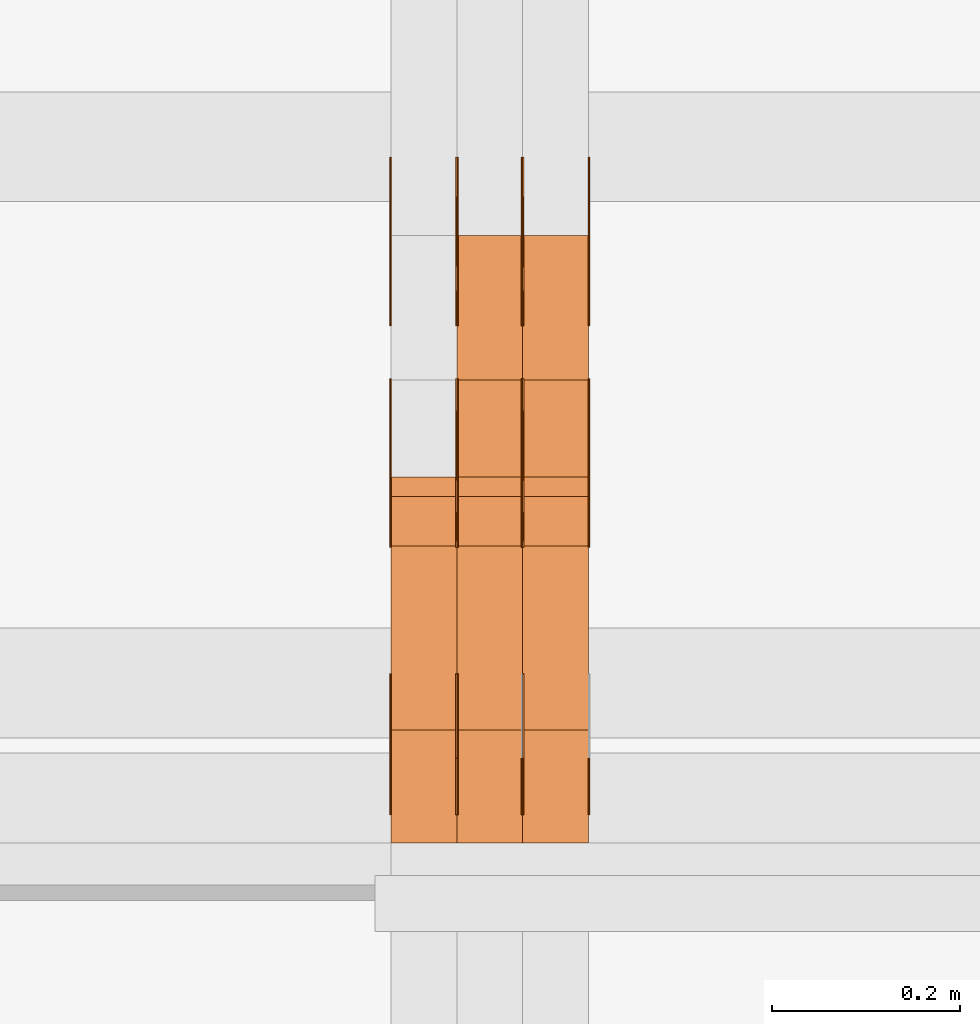
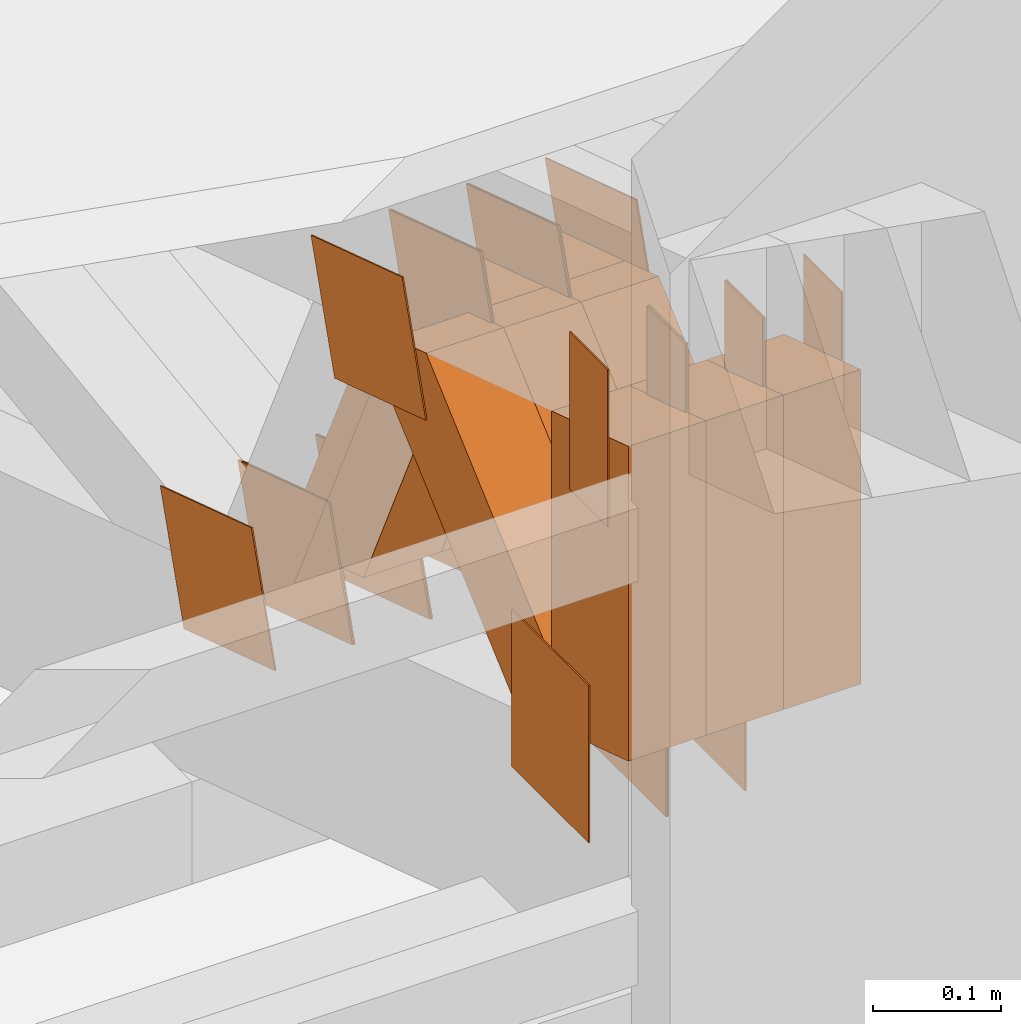
# One storey, part 150 of 385: 30 proxies.
"""IFC2X3 building model written with IfcOpenShell, lengths in millimetres."""

from ifc_helpers import new_model, entity, si_unit, converted_unit, derived_unit, direction, frame, origin, origin_2d_with_axis, place, context, subcontext, project, spatial, polyline, rectangle, outline, extrude, source, transform, mapped, material, type_object, type_shapes, element, save


model = new_model("IFC2X3")

# Units and contexts
model_context = context("Model", 3, precision=0.01, world=origin(), true_north=direction((6.12303176911189e-17, 1.0)))
body_context = subcontext(model_context, "Body", "Model", "MODEL_VIEW")
ifc_project = project(units=[si_unit("LENGTHUNIT", "METRE", prefix="MILLI"), si_unit("AREAUNIT", "SQUARE_METRE"), si_unit("VOLUMEUNIT", "CUBIC_METRE"), converted_unit("PLANEANGLEUNIT", "DEGREE", entity("IfcRatioMeasure", 0.0174532925199433), si_unit("PLANEANGLEUNIT", "RADIAN"), dimensions=[0, 0, 0, 0, 0, 0, 0]), si_unit("MASSUNIT", "GRAM", prefix="KILO"), derived_unit("MASSDENSITYUNIT", [(si_unit("MASSUNIT", "GRAM", prefix="KILO"), 1), (si_unit("LENGTHUNIT", "METRE"), -3)]), si_unit("TIMEUNIT", "SECOND"), si_unit("FREQUENCYUNIT", "HERTZ"), si_unit("THERMODYNAMICTEMPERATUREUNIT", "DEGREE_CELSIUS"), derived_unit("THERMALTRANSMITTANCEUNIT", [(si_unit("MASSUNIT", "GRAM", prefix="KILO"), 1), (si_unit("THERMODYNAMICTEMPERATUREUNIT", "KELVIN"), -1), (si_unit("TIMEUNIT", "SECOND"), -3)]), derived_unit("VOLUMETRICFLOWRATEUNIT", [(si_unit("LENGTHUNIT", "METRE"), 3), (si_unit("TIMEUNIT", "SECOND"), -1)]), si_unit("ELECTRICCURRENTUNIT", "AMPERE"), si_unit("ELECTRICVOLTAGEUNIT", "VOLT"), si_unit("POWERUNIT", "WATT"), si_unit("FORCEUNIT", "NEWTON", prefix="KILO"), si_unit("ILLUMINANCEUNIT", "LUX"), si_unit("LUMINOUSFLUXUNIT", "LUMEN"), si_unit("LUMINOUSINTENSITYUNIT", "CANDELA"), derived_unit("USERDEFINED", [(si_unit("MASSUNIT", "GRAM", prefix="KILO"), -1), (si_unit("LENGTHUNIT", "METRE"), -2), (si_unit("TIMEUNIT", "SECOND"), 3), (si_unit("LUMINOUSFLUXUNIT", "LUMEN"), 1)]), derived_unit("LINEARVELOCITYUNIT", [(si_unit("LENGTHUNIT", "METRE"), 1), (si_unit("TIMEUNIT", "SECOND"), -1)]), si_unit("PRESSUREUNIT", "PASCAL"), derived_unit("USERDEFINED", [(si_unit("LENGTHUNIT", "METRE"), -2), (si_unit("MASSUNIT", "GRAM", prefix="KILO"), 1), (si_unit("TIMEUNIT", "SECOND"), -2)])], contexts=[model_context])

# Site, building, storey
site_placement = place(None, origin())
site = spatial("IfcSite", under=ifc_project, at=site_placement, CompositionType="ELEMENT")
building_placement = place(site_placement, origin())
building = spatial("IfcBuilding", under=site, at=building_placement, CompositionType="ELEMENT")
storey_placement = place(building_placement, origin())
storey = spatial("IfcBuildingStorey", under=building, at=storey_placement, Name="Default", CompositionType="ELEMENT", Elevation=0.0)

# Proxies
ifc_material_1 = material(Name="IfcSurfaceStyle #274128")
building_element_proxy_type_1 = type_object("IfcBuildingElementProxyType", PredefinedType="NOTDEFINED", material=ifc_material_1)
shared_shape_1 = source(origin(), body_context, "Body", "SweptSolid", [
    extrude(rectangle(XDim=150.0, YDim=120.0, at=origin_2d_with_axis()), frame((75.0, 60.0, 0.0), z_axis=(0.0, 0.0, 1.0), x_axis=(-1.0, 0.0, 0.0)), (0.0, 0.0, 1.0), 1.3),
])
type_shapes(building_element_proxy_type_1, [shared_shape_1])
proxy_1_placement = place(building_placement, frame((21316.3, 15840.0, 3652.70166015625), z_axis=(-1.0, 0.0, 0.0), x_axis=(0.0, 0.0, -1.0)))
element("IfcBuildingElementProxy", 1, at=proxy_1_placement, inside=storey, type_object=building_element_proxy_type_1, material=ifc_material_1, context=body_context, shape_type="MappedRepresentation", body=[
    mapped(shared_shape_1, transform((0.0, 0.0, 0.0), scale=1.0)),
])
ifc_material_2 = material(Name="IfcSurfaceStyle #274071")
building_element_proxy_type_2 = type_object("IfcBuildingElementProxyType", PredefinedType="NOTDEFINED", material=ifc_material_2)
shared_shape_2 = source(origin(), body_context, "Body", "SweptSolid", [
    extrude(rectangle(XDim=150.0, YDim=120.0, at=origin_2d_with_axis()), frame((75.0, 60.0, 0.0), z_axis=(0.0, 0.0, 1.0), x_axis=(-1.0, 0.0, 0.0)), (0.0, 0.0, 1.0), 1.29999999999999),
])
type_shapes(building_element_proxy_type_2, [shared_shape_2])
proxy_2_placement = place(building_placement, frame((21245.0, 15840.0, 3652.70166015625), z_axis=(-1.0, 0.0, 0.0), x_axis=(0.0, 0.0, -1.0)))
element("IfcBuildingElementProxy", 2, at=proxy_2_placement, inside=storey, type_object=building_element_proxy_type_2, material=ifc_material_2, context=body_context, shape_type="MappedRepresentation", body=[
    mapped(shared_shape_2, transform((0.0, 0.0, 0.0), scale=1.0)),
])
ifc_material_3 = material(Name="IfcSurfaceStyle #274014")
building_element_proxy_type_3 = type_object("IfcBuildingElementProxyType", PredefinedType="NOTDEFINED", material=ifc_material_3)
shared_shape_3 = source(origin(), body_context, "Body", "SweptSolid", [
    extrude(rectangle(XDim=150.0, YDim=120.0, at=origin_2d_with_axis()), frame((75.0, 60.0, 0.0), z_axis=(0.0, 0.0, 1.0), x_axis=(-1.0, 0.0, 0.0)), (0.0, 0.0, 1.0), 1.29999999999999),
])
type_shapes(building_element_proxy_type_3, [shared_shape_3])
proxy_3_placement = place(building_placement, frame((21246.3, 15840.0, 3652.70166015625), z_axis=(-1.0, 0.0, 0.0), x_axis=(0.0, 0.0, -1.0)))
element("IfcBuildingElementProxy", 3, at=proxy_3_placement, inside=storey, type_object=building_element_proxy_type_3, material=ifc_material_3, context=body_context, shape_type="MappedRepresentation", body=[
    mapped(shared_shape_3, transform((0.0, 0.0, 0.0), scale=1.0)),
])
ifc_material_4 = material(Name="IfcSurfaceStyle #273957")
building_element_proxy_type_4 = type_object("IfcBuildingElementProxyType", PredefinedType="NOTDEFINED", material=ifc_material_4)
shared_shape_4 = source(origin(), body_context, "Body", "SweptSolid", [
    extrude(rectangle(XDim=150.0, YDim=120.0, at=origin_2d_with_axis()), frame((75.0, 60.0, 0.0), z_axis=(0.0, 0.0, 1.0), x_axis=(-1.0, 0.0, 0.0)), (0.0, 0.0, 1.0), 1.29999999999999),
])
type_shapes(building_element_proxy_type_4, [shared_shape_4])
proxy_4_placement = place(building_placement, frame((21175.0, 15840.0, 3652.70166015625), z_axis=(-1.0, 0.0, 0.0), x_axis=(0.0, 0.0, -1.0)))
element("IfcBuildingElementProxy", 4, at=proxy_4_placement, inside=storey, type_object=building_element_proxy_type_4, material=ifc_material_4, context=body_context, shape_type="MappedRepresentation", body=[
    mapped(shared_shape_4, transform((0.0, 0.0, 0.0), scale=1.0)),
])
ifc_material_5 = material(Name="IfcSurfaceStyle #273900")
building_element_proxy_type_5 = type_object("IfcBuildingElementProxyType", PredefinedType="NOTDEFINED", material=ifc_material_5)
shared_shape_5 = source(origin(), body_context, "Body", "SweptSolid", [
    extrude(outline(polyline([(-74.9998605591118, -59.9999264677601), (74.9998754286171, -59.9999264677601), (74.9998605591118, 59.9999264677602), (-74.9998754286171, 59.9999264677602), (-74.9998605591118, -59.9999264677601)])), frame((74.9998754286171, 60.0000503992849, 0.0), z_axis=(0.0, 0.0, 1.0), x_axis=(-1.0, 0.0, 0.0)), (0.0, 0.0, 1.0), 1.3),
])
type_shapes(building_element_proxy_type_5, [shared_shape_5])
proxy_5_placement = place(building_placement, frame((21386.3, 16352.8320303235, 3323.23212676408), z_axis=(-1.0, 0.0, 0.0), x_axis=(0.0, -0.951056516295124, 0.309016994375039)))
element("IfcBuildingElementProxy", 5, at=proxy_5_placement, inside=storey, type_object=building_element_proxy_type_5, material=ifc_material_5, context=body_context, shape_type="MappedRepresentation", body=[
    mapped(shared_shape_5, transform((0.0, 0.0, 0.0), scale=1.0)),
])
ifc_material_6 = material(Name="IfcSurfaceStyle #273843")
building_element_proxy_type_6 = type_object("IfcBuildingElementProxyType", PredefinedType="NOTDEFINED", material=ifc_material_6)
shared_shape_6 = source(origin(), body_context, "Body", "SweptSolid", [
    extrude(outline(polyline([(-74.9998605591118, -59.9999264677601), (74.9998754286171, -59.9999264677601), (74.9998605591118, 59.9999264677602), (-74.9998754286171, 59.9999264677602), (-74.9998605591118, -59.9999264677601)])), frame((74.9998754286171, 60.0000503992849, 0.0), z_axis=(0.0, 0.0, 1.0), x_axis=(-1.0, 0.0, 0.0)), (0.0, 0.0, 1.0), 1.3),
])
type_shapes(building_element_proxy_type_6, [shared_shape_6])
proxy_6_placement = place(building_placement, frame((21315.0, 16352.8320303235, 3323.23212676408), z_axis=(-1.0, 0.0, 0.0), x_axis=(0.0, -0.951056516295124, 0.309016994375039)))
element("IfcBuildingElementProxy", 6, at=proxy_6_placement, inside=storey, type_object=building_element_proxy_type_6, material=ifc_material_6, context=body_context, shape_type="MappedRepresentation", body=[
    mapped(shared_shape_6, transform((0.0, 0.0, 0.0), scale=1.0)),
])
ifc_material_7 = material(Name="IfcSurfaceStyle #273786")
building_element_proxy_type_7 = type_object("IfcBuildingElementProxyType", PredefinedType="NOTDEFINED", material=ifc_material_7)
shared_shape_7 = source(origin(), body_context, "Body", "SweptSolid", [
    extrude(outline(polyline([(-74.9998605591118, -59.9999264677601), (74.9998754286171, -59.9999264677601), (74.9998605591118, 59.9999264677602), (-74.9998754286171, 59.9999264677602), (-74.9998605591118, -59.9999264677601)])), frame((74.9998754286171, 60.0000503992849, 0.0), z_axis=(0.0, 0.0, 1.0), x_axis=(-1.0, 0.0, 0.0)), (0.0, 0.0, 1.0), 1.3),
])
type_shapes(building_element_proxy_type_7, [shared_shape_7])
proxy_7_placement = place(building_placement, frame((21316.3, 16352.8320303235, 3323.23212676408), z_axis=(-1.0, 0.0, 0.0), x_axis=(0.0, -0.951056516295124, 0.309016994375039)))
element("IfcBuildingElementProxy", 7, at=proxy_7_placement, inside=storey, type_object=building_element_proxy_type_7, material=ifc_material_7, context=body_context, shape_type="MappedRepresentation", body=[
    mapped(shared_shape_7, transform((0.0, 0.0, 0.0), scale=1.0)),
])
ifc_material_8 = material(Name="IfcSurfaceStyle #273729")
building_element_proxy_type_8 = type_object("IfcBuildingElementProxyType", PredefinedType="NOTDEFINED", material=ifc_material_8)
shared_shape_8 = source(origin(), body_context, "Body", "SweptSolid", [
    extrude(outline(polyline([(-74.9998605591118, -59.9999264677601), (74.9998754286171, -59.9999264677601), (74.9998605591118, 59.9999264677602), (-74.9998754286171, 59.9999264677602), (-74.9998605591118, -59.9999264677601)])), frame((74.9998754286171, 60.0000503992849, 0.0), z_axis=(0.0, 0.0, 1.0), x_axis=(-1.0, 0.0, 0.0)), (0.0, 0.0, 1.0), 1.29999999999999),
])
type_shapes(building_element_proxy_type_8, [shared_shape_8])
proxy_8_placement = place(building_placement, frame((21245.0, 16352.8320303235, 3323.23212676408), z_axis=(-1.0, 0.0, 0.0), x_axis=(0.0, -0.951056516295124, 0.309016994375039)))
element("IfcBuildingElementProxy", 8, at=proxy_8_placement, inside=storey, type_object=building_element_proxy_type_8, material=ifc_material_8, context=body_context, shape_type="MappedRepresentation", body=[
    mapped(shared_shape_8, transform((0.0, 0.0, 0.0), scale=1.0)),
])
ifc_material_9 = material(Name="IfcSurfaceStyle #273672")
building_element_proxy_type_9 = type_object("IfcBuildingElementProxyType", PredefinedType="NOTDEFINED", material=ifc_material_9)
shared_shape_9 = source(origin(), body_context, "Body", "SweptSolid", [
    extrude(outline(polyline([(-74.9998605591118, -59.9999264677601), (74.9998754286171, -59.9999264677601), (74.9998605591118, 59.9999264677602), (-74.9998754286171, 59.9999264677602), (-74.9998605591118, -59.9999264677601)])), frame((74.9998754286171, 60.0000503992849, 0.0), z_axis=(0.0, 0.0, 1.0), x_axis=(-1.0, 0.0, 0.0)), (0.0, 0.0, 1.0), 1.29999999999999),
])
type_shapes(building_element_proxy_type_9, [shared_shape_9])
proxy_9_placement = place(building_placement, frame((21246.3, 16352.8320303235, 3323.23212676408), z_axis=(-1.0, 0.0, 0.0), x_axis=(0.0, -0.951056516295124, 0.309016994375039)))
element("IfcBuildingElementProxy", 9, at=proxy_9_placement, inside=storey, type_object=building_element_proxy_type_9, material=ifc_material_9, context=body_context, shape_type="MappedRepresentation", body=[
    mapped(shared_shape_9, transform((0.0, 0.0, 0.0), scale=1.0)),
])
ifc_material_10 = material(Name="IfcSurfaceStyle #273615")
building_element_proxy_type_10 = type_object("IfcBuildingElementProxyType", PredefinedType="NOTDEFINED", material=ifc_material_10)
shared_shape_10 = source(origin(), body_context, "Body", "SweptSolid", [
    extrude(outline(polyline([(-74.9998605591118, -59.9999264677601), (74.9998754286171, -59.9999264677601), (74.9998605591118, 59.9999264677602), (-74.9998754286171, 59.9999264677602), (-74.9998605591118, -59.9999264677601)])), frame((74.9998754286171, 60.0000503992849, 0.0), z_axis=(0.0, 0.0, 1.0), x_axis=(-1.0, 0.0, 0.0)), (0.0, 0.0, 1.0), 1.29999999999999),
])
type_shapes(building_element_proxy_type_10, [shared_shape_10])
proxy_10_placement = place(building_placement, frame((21175.0, 16352.8320303235, 3323.23212676408), z_axis=(-1.0, 0.0, 0.0), x_axis=(0.0, -0.951056516295124, 0.309016994375039)))
element("IfcBuildingElementProxy", 10, at=proxy_10_placement, inside=storey, type_object=building_element_proxy_type_10, material=ifc_material_10, context=body_context, shape_type="MappedRepresentation", body=[
    mapped(shared_shape_10, transform((0.0, 0.0, 0.0), scale=1.0)),
])
ifc_material_11 = material(Name="IfcSurfaceStyle #269454")
building_element_proxy_type_11 = type_object("IfcBuildingElementProxyType", PredefinedType="NOTDEFINED", material=ifc_material_11)
shared_shape_11 = source(origin(), body_context, "Body", "SweptSolid", [
    extrude(outline(polyline([(-75.0003249421702, -60.0000773549573), (75.0003398116874, -60.0000773549573), (75.0003249421711, 60.0000773549573), (-75.0003398116883, 60.0000773549573), (-75.0003249421702, -60.0000773549573)])), frame((75.0003398116874, 60.0000773549573, 0.0), z_axis=(0.0, 0.0, 1.0), x_axis=(-1.0, 0.0, 0.0)), (0.0, 0.0, 1.0), 1.3),
])
type_shapes(building_element_proxy_type_11, [shared_shape_11])
proxy_11_placement = place(building_placement, frame((21386.3, 16117.0849050545, 3705.49074668796), z_axis=(-1.0, 0.0, 0.0), x_axis=(0.0, -0.951056516295154, 0.309016994374948)))
element("IfcBuildingElementProxy", 11, at=proxy_11_placement, inside=storey, type_object=building_element_proxy_type_11, material=ifc_material_11, context=body_context, shape_type="MappedRepresentation", body=[
    mapped(shared_shape_11, transform((0.0, 0.0, 0.0), scale=1.0)),
])
ifc_material_12 = material(Name="IfcSurfaceStyle #269397")
building_element_proxy_type_12 = type_object("IfcBuildingElementProxyType", PredefinedType="NOTDEFINED", material=ifc_material_12)
shared_shape_12 = source(origin(), body_context, "Body", "SweptSolid", [
    extrude(outline(polyline([(-75.0003249421702, -60.0000773549573), (75.0003398116874, -60.0000773549573), (75.0003249421711, 60.0000773549573), (-75.0003398116883, 60.0000773549573), (-75.0003249421702, -60.0000773549573)])), frame((75.0003398116874, 60.0000773549573, 0.0), z_axis=(0.0, 0.0, 1.0), x_axis=(-1.0, 0.0, 0.0)), (0.0, 0.0, 1.0), 1.3),
])
type_shapes(building_element_proxy_type_12, [shared_shape_12])
proxy_12_placement = place(building_placement, frame((21315.0, 16117.0849050545, 3705.49074668796), z_axis=(-1.0, 0.0, 0.0), x_axis=(0.0, -0.951056516295154, 0.309016994374948)))
element("IfcBuildingElementProxy", 12, at=proxy_12_placement, inside=storey, type_object=building_element_proxy_type_12, material=ifc_material_12, context=body_context, shape_type="MappedRepresentation", body=[
    mapped(shared_shape_12, transform((0.0, 0.0, 0.0), scale=1.0)),
])
ifc_material_13 = material(Name="IfcSurfaceStyle #269340")
building_element_proxy_type_13 = type_object("IfcBuildingElementProxyType", PredefinedType="NOTDEFINED", material=ifc_material_13)
shared_shape_13 = source(origin(), body_context, "Body", "SweptSolid", [
    extrude(outline(polyline([(-75.0003249421702, -60.0000773549573), (75.0003398116874, -60.0000773549573), (75.0003249421711, 60.0000773549573), (-75.0003398116883, 60.0000773549573), (-75.0003249421702, -60.0000773549573)])), frame((75.0003398116874, 60.0000773549573, 0.0), z_axis=(0.0, 0.0, 1.0), x_axis=(-1.0, 0.0, 0.0)), (0.0, 0.0, 1.0), 1.3),
])
type_shapes(building_element_proxy_type_13, [shared_shape_13])
proxy_13_placement = place(building_placement, frame((21316.3, 16117.0849050545, 3705.49074668796), z_axis=(-1.0, 0.0, 0.0), x_axis=(0.0, -0.951056516295154, 0.309016994374948)))
element("IfcBuildingElementProxy", 13, at=proxy_13_placement, inside=storey, type_object=building_element_proxy_type_13, material=ifc_material_13, context=body_context, shape_type="MappedRepresentation", body=[
    mapped(shared_shape_13, transform((0.0, 0.0, 0.0), scale=1.0)),
])
ifc_material_14 = material(Name="IfcSurfaceStyle #269283")
building_element_proxy_type_14 = type_object("IfcBuildingElementProxyType", PredefinedType="NOTDEFINED", material=ifc_material_14)
shared_shape_14 = source(origin(), body_context, "Body", "SweptSolid", [
    extrude(outline(polyline([(-75.0003249421702, -60.0000773549573), (75.0003398116874, -60.0000773549573), (75.0003249421711, 60.0000773549573), (-75.0003398116883, 60.0000773549573), (-75.0003249421702, -60.0000773549573)])), frame((75.0003398116874, 60.0000773549573, 0.0), z_axis=(0.0, 0.0, 1.0), x_axis=(-1.0, 0.0, 0.0)), (0.0, 0.0, 1.0), 1.29999999999999),
])
type_shapes(building_element_proxy_type_14, [shared_shape_14])
proxy_14_placement = place(building_placement, frame((21245.0, 16117.0849050545, 3705.49074668796), z_axis=(-1.0, 0.0, 0.0), x_axis=(0.0, -0.951056516295154, 0.309016994374948)))
element("IfcBuildingElementProxy", 14, at=proxy_14_placement, inside=storey, type_object=building_element_proxy_type_14, material=ifc_material_14, context=body_context, shape_type="MappedRepresentation", body=[
    mapped(shared_shape_14, transform((0.0, 0.0, 0.0), scale=1.0)),
])
ifc_material_15 = material(Name="IfcSurfaceStyle #269226")
building_element_proxy_type_15 = type_object("IfcBuildingElementProxyType", PredefinedType="NOTDEFINED", material=ifc_material_15)
shared_shape_15 = source(origin(), body_context, "Body", "SweptSolid", [
    extrude(outline(polyline([(-75.0003249421702, -60.0000773549573), (75.0003398116874, -60.0000773549573), (75.0003249421711, 60.0000773549573), (-75.0003398116883, 60.0000773549573), (-75.0003249421702, -60.0000773549573)])), frame((75.0003398116874, 60.0000773549573, 0.0), z_axis=(0.0, 0.0, 1.0), x_axis=(-1.0, 0.0, 0.0)), (0.0, 0.0, 1.0), 1.29999999999999),
])
type_shapes(building_element_proxy_type_15, [shared_shape_15])
proxy_15_placement = place(building_placement, frame((21246.3, 16117.0849050545, 3705.49074668796), z_axis=(-1.0, 0.0, 0.0), x_axis=(0.0, -0.951056516295154, 0.309016994374948)))
element("IfcBuildingElementProxy", 15, at=proxy_15_placement, inside=storey, type_object=building_element_proxy_type_15, material=ifc_material_15, context=body_context, shape_type="MappedRepresentation", body=[
    mapped(shared_shape_15, transform((0.0, 0.0, 0.0), scale=1.0)),
])
ifc_material_16 = material(Name="IfcSurfaceStyle #269169")
building_element_proxy_type_16 = type_object("IfcBuildingElementProxyType", PredefinedType="NOTDEFINED", material=ifc_material_16)
shared_shape_16 = source(origin(), body_context, "Body", "SweptSolid", [
    extrude(outline(polyline([(-75.0003249421702, -60.0000773549573), (75.0003398116874, -60.0000773549573), (75.0003249421711, 60.0000773549573), (-75.0003398116883, 60.0000773549573), (-75.0003249421702, -60.0000773549573)])), frame((75.0003398116874, 60.0000773549573, 0.0), z_axis=(0.0, 0.0, 1.0), x_axis=(-1.0, 0.0, 0.0)), (0.0, 0.0, 1.0), 1.29999999999999),
])
type_shapes(building_element_proxy_type_16, [shared_shape_16])
proxy_16_placement = place(building_placement, frame((21175.0, 16117.0849050545, 3705.49074668796), z_axis=(-1.0, 0.0, 0.0), x_axis=(0.0, -0.951056516295154, 0.309016994374948)))
element("IfcBuildingElementProxy", 16, at=proxy_16_placement, inside=storey, type_object=building_element_proxy_type_16, material=ifc_material_16, context=body_context, shape_type="MappedRepresentation", body=[
    mapped(shared_shape_16, transform((0.0, 0.0, 0.0), scale=1.0)),
])
ifc_material_17 = material(Name="IfcSurfaceStyle #268770")
building_element_proxy_type_17 = type_object("IfcBuildingElementProxyType", PredefinedType="NOTDEFINED", material=ifc_material_17)
shared_shape_17 = source(origin(), body_context, "Body", "SweptSolid", [
    extrude(rectangle(XDim=150.0, YDim=60.0, at=origin_2d_with_axis()), frame((75.0000705696311, 30.0, 0.0), z_axis=(0.0, 0.0, 1.0), x_axis=(-1.0, 0.0, 0.0)), (0.0, 0.0, 1.0), 1.3),
])
type_shapes(building_element_proxy_type_17, [shared_shape_17])
proxy_17_placement = place(building_placement, frame((21386.3, 15750.0, 3972.59919166338), z_axis=(-1.0, 0.0, 0.0), x_axis=(0.0, 0.0, -1.0)))
element("IfcBuildingElementProxy", 17, at=proxy_17_placement, inside=storey, type_object=building_element_proxy_type_17, material=ifc_material_17, context=body_context, shape_type="MappedRepresentation", body=[
    mapped(shared_shape_17, transform((0.0, 0.0, 0.0), scale=1.0)),
])
ifc_material_18 = material(Name="IfcSurfaceStyle #268713")
building_element_proxy_type_18 = type_object("IfcBuildingElementProxyType", PredefinedType="NOTDEFINED", material=ifc_material_18)
shared_shape_18 = source(origin(), body_context, "Body", "SweptSolid", [
    extrude(rectangle(XDim=150.0, YDim=60.0, at=origin_2d_with_axis()), frame((75.0000705696311, 30.0, 0.0), z_axis=(0.0, 0.0, 1.0), x_axis=(-1.0, 0.0, 0.0)), (0.0, 0.0, 1.0), 1.3),
])
type_shapes(building_element_proxy_type_18, [shared_shape_18])
proxy_18_placement = place(building_placement, frame((21315.0, 15750.0, 3972.59919166338), z_axis=(-1.0, 0.0, 0.0), x_axis=(0.0, 0.0, -1.0)))
element("IfcBuildingElementProxy", 18, at=proxy_18_placement, inside=storey, type_object=building_element_proxy_type_18, material=ifc_material_18, context=body_context, shape_type="MappedRepresentation", body=[
    mapped(shared_shape_18, transform((0.0, 0.0, 0.0), scale=1.0)),
])
ifc_material_19 = material(Name="IfcSurfaceStyle #268656")
building_element_proxy_type_19 = type_object("IfcBuildingElementProxyType", PredefinedType="NOTDEFINED", material=ifc_material_19)
shared_shape_19 = source(origin(), body_context, "Body", "SweptSolid", [
    extrude(rectangle(XDim=150.0, YDim=60.0, at=origin_2d_with_axis()), frame((75.0000705696311, 30.0, 0.0), z_axis=(0.0, 0.0, 1.0), x_axis=(-1.0, 0.0, 0.0)), (0.0, 0.0, 1.0), 1.3),
])
type_shapes(building_element_proxy_type_19, [shared_shape_19])
proxy_19_placement = place(building_placement, frame((21316.3, 15750.0, 3972.59919166338), z_axis=(-1.0, 0.0, 0.0), x_axis=(0.0, 0.0, -1.0)))
element("IfcBuildingElementProxy", 19, at=proxy_19_placement, inside=storey, type_object=building_element_proxy_type_19, material=ifc_material_19, context=body_context, shape_type="MappedRepresentation", body=[
    mapped(shared_shape_19, transform((0.0, 0.0, 0.0), scale=1.0)),
])
ifc_material_20 = material(Name="IfcSurfaceStyle #268599")
building_element_proxy_type_20 = type_object("IfcBuildingElementProxyType", PredefinedType="NOTDEFINED", material=ifc_material_20)
shared_shape_20 = source(origin(), body_context, "Body", "SweptSolid", [
    extrude(rectangle(XDim=150.0, YDim=60.0, at=origin_2d_with_axis()), frame((75.0000705696311, 30.0, 0.0), z_axis=(0.0, 0.0, 1.0), x_axis=(-1.0, 0.0, 0.0)), (0.0, 0.0, 1.0), 1.29999999999999),
])
type_shapes(building_element_proxy_type_20, [shared_shape_20])
proxy_20_placement = place(building_placement, frame((21245.0, 15750.0, 3972.59919166338), z_axis=(-1.0, 0.0, 0.0), x_axis=(0.0, 0.0, -1.0)))
element("IfcBuildingElementProxy", 20, at=proxy_20_placement, inside=storey, type_object=building_element_proxy_type_20, material=ifc_material_20, context=body_context, shape_type="MappedRepresentation", body=[
    mapped(shared_shape_20, transform((0.0, 0.0, 0.0), scale=1.0)),
])
ifc_material_21 = material(Name="IfcSurfaceStyle #268542")
building_element_proxy_type_21 = type_object("IfcBuildingElementProxyType", PredefinedType="NOTDEFINED", material=ifc_material_21)
shared_shape_21 = source(origin(), body_context, "Body", "SweptSolid", [
    extrude(rectangle(XDim=150.0, YDim=60.0, at=origin_2d_with_axis()), frame((75.0000705696311, 30.0, 0.0), z_axis=(0.0, 0.0, 1.0), x_axis=(-1.0, 0.0, 0.0)), (0.0, 0.0, 1.0), 1.29999999999999),
])
type_shapes(building_element_proxy_type_21, [shared_shape_21])
proxy_21_placement = place(building_placement, frame((21246.3, 15750.0, 3972.59919166338), z_axis=(-1.0, 0.0, 0.0), x_axis=(0.0, 0.0, -1.0)))
element("IfcBuildingElementProxy", 21, at=proxy_21_placement, inside=storey, type_object=building_element_proxy_type_21, material=ifc_material_21, context=body_context, shape_type="MappedRepresentation", body=[
    mapped(shared_shape_21, transform((0.0, 0.0, 0.0), scale=1.0)),
])
ifc_material_22 = material(Name="IfcSurfaceStyle #268485")
building_element_proxy_type_22 = type_object("IfcBuildingElementProxyType", PredefinedType="NOTDEFINED", material=ifc_material_22)
shared_shape_22 = source(origin(), body_context, "Body", "SweptSolid", [
    extrude(rectangle(XDim=150.0, YDim=60.0, at=origin_2d_with_axis()), frame((75.0000705696311, 30.0, 0.0), z_axis=(0.0, 0.0, 1.0), x_axis=(-1.0, 0.0, 0.0)), (0.0, 0.0, 1.0), 1.29999999999999),
])
type_shapes(building_element_proxy_type_22, [shared_shape_22])
proxy_22_placement = place(building_placement, frame((21175.0, 15750.0, 3972.59919166338), z_axis=(-1.0, 0.0, 0.0), x_axis=(0.0, 0.0, -1.0)))
element("IfcBuildingElementProxy", 22, at=proxy_22_placement, inside=storey, type_object=building_element_proxy_type_22, material=ifc_material_22, context=body_context, shape_type="MappedRepresentation", body=[
    mapped(shared_shape_22, transform((0.0, 0.0, 0.0), scale=1.0)),
])
ifc_material_23 = material(Name="IfcSurfaceStyle #259401")
building_element_proxy_type_23 = type_object("IfcBuildingElementProxyType", Name="T1-W50 259399", PredefinedType="NOTDEFINED", material=ifc_material_23)
shared_shape_23 = source(origin(), body_context, "Body", "SweptSolid", [
    extrude(outline(polyline([(-128.56619634284, -47.4999385885712), (133.151257249084, -47.4999385885712), (161.172800006526, -0.000129729183733609), (147.291467726413, 47.500068317755), (-142.513973767368, 47.500068317755), (-170.535354871815, -0.000129729183754689), (-128.56619634284, -47.4999385885712)])), frame((161.17310141218, 47.5001898716564, 0.0), z_axis=(0.0, 0.0, 1.0), x_axis=(-1.0, 0.0, 0.0)), (0.0, 0.0, 1.0), 70.0),
])
type_shapes(building_element_proxy_type_23, [shared_shape_23])
proxy_23_placement = place(building_placement, frame((21385.0, 16060.0297689714, 3761.73994820667), z_axis=(-1.0, 0.0, 0.0), x_axis=(0.0, -0.749388407538668, -0.662130662820156)))
element("IfcBuildingElementProxy", 23, at=proxy_23_placement, inside=storey, type_object=building_element_proxy_type_23, material=ifc_material_23, Name="T1-W50", context=body_context, shape_type="MappedRepresentation", body=[
    mapped(shared_shape_23, transform((0.0, 0.0, 0.0), scale=1.0)),
])
ifc_material_24 = material(Name="IfcSurfaceStyle #259326")
building_element_proxy_type_24 = type_object("IfcBuildingElementProxyType", Name="T1-W50 259324", PredefinedType="NOTDEFINED", material=ifc_material_24)
shared_shape_24 = source(origin(), body_context, "Body", "SweptSolid", [
    extrude(outline(polyline([(-128.56619634284, -47.4999385885712), (133.151257249084, -47.4999385885712), (161.172800006526, -0.000129729183733609), (147.291467726413, 47.500068317755), (-142.513973767368, 47.500068317755), (-170.535354871815, -0.000129729183754689), (-128.56619634284, -47.4999385885712)])), frame((161.17310141218, 47.5001898716564, 0.0), z_axis=(0.0, 0.0, 1.0), x_axis=(-1.0, 0.0, 0.0)), (0.0, 0.0, 1.0), 70.0),
])
type_shapes(building_element_proxy_type_24, [shared_shape_24])
proxy_24_placement = place(building_placement, frame((21315.0, 16060.0297689714, 3761.73994820667), z_axis=(-1.0, 0.0, 0.0), x_axis=(0.0, -0.749388407538668, -0.662130662820156)))
element("IfcBuildingElementProxy", 24, at=proxy_24_placement, inside=storey, type_object=building_element_proxy_type_24, material=ifc_material_24, Name="T1-W50", context=body_context, shape_type="MappedRepresentation", body=[
    mapped(shared_shape_24, transform((0.0, 0.0, 0.0), scale=1.0)),
])
ifc_material_25 = material(Name="IfcSurfaceStyle #259251")
building_element_proxy_type_25 = type_object("IfcBuildingElementProxyType", Name="T1-W50 259249", PredefinedType="NOTDEFINED", material=ifc_material_25)
shared_shape_25 = source(origin(), body_context, "Body", "SweptSolid", [
    extrude(outline(polyline([(-128.56619634284, -47.4999385885712), (133.151257249084, -47.4999385885712), (161.172800006526, -0.000129729183733609), (147.291467726413, 47.500068317755), (-142.513973767368, 47.500068317755), (-170.535354871815, -0.000129729183754689), (-128.56619634284, -47.4999385885712)])), frame((161.17310141218, 47.5001898716564, 0.0), z_axis=(0.0, 0.0, 1.0), x_axis=(-1.0, 0.0, 0.0)), (0.0, 0.0, 1.0), 70.0),
])
type_shapes(building_element_proxy_type_25, [shared_shape_25])
proxy_25_placement = place(building_placement, frame((21245.0, 16060.0297689714, 3761.73994820667), z_axis=(-1.0, 0.0, 0.0), x_axis=(0.0, -0.749388407538668, -0.662130662820156)))
element("IfcBuildingElementProxy", 25, at=proxy_25_placement, inside=storey, type_object=building_element_proxy_type_25, material=ifc_material_25, Name="T1-W50", context=body_context, shape_type="MappedRepresentation", body=[
    mapped(shared_shape_25, transform((0.0, 0.0, 0.0), scale=1.0)),
])
ifc_material_26 = material(Name="IfcSurfaceStyle #259005")
building_element_proxy_type_26 = type_object("IfcBuildingElementProxyType", Name="T1-W2 259003", PredefinedType="NOTDEFINED", material=ifc_material_26)
shared_shape_26 = source(origin(), body_context, "Body", "SweptSolid", [
    extrude(outline(polyline([(-130.705993652344, -60.0), (169.696350097656, -60.0), (130.706115722656, 60.0), (-169.696472167969, 60.0), (-130.705993652344, -60.0)])), frame((169.696429629256, 60.0, 0.0), z_axis=(0.0, 0.0, 1.0), x_axis=(-1.0, 0.0, 0.0)), (0.0, 0.0, 1.0), 70.0),
])
type_shapes(building_element_proxy_type_26, [shared_shape_26])
proxy_26_placement = place(building_placement, frame((21385.0, 15660.0, 3577.70158062465), z_axis=(-1.0, 0.0, 0.0), x_axis=(0.0, 0.0, 1.0)))
element("IfcBuildingElementProxy", 26, at=proxy_26_placement, inside=storey, type_object=building_element_proxy_type_26, material=ifc_material_26, Name="T1-W2", context=body_context, shape_type="MappedRepresentation", body=[
    mapped(shared_shape_26, transform((0.0, 0.0, 0.0), scale=1.0)),
])
ifc_material_27 = material(Name="IfcSurfaceStyle #258948")
building_element_proxy_type_27 = type_object("IfcBuildingElementProxyType", Name="T1-W2 258946", PredefinedType="NOTDEFINED", material=ifc_material_27)
shared_shape_27 = source(origin(), body_context, "Body", "SweptSolid", [
    extrude(outline(polyline([(-130.705993652344, -60.0), (169.696350097656, -60.0), (130.706115722656, 60.0), (-169.696472167969, 60.0), (-130.705993652344, -60.0)])), frame((169.696429629256, 60.0, 0.0), z_axis=(0.0, 0.0, 1.0), x_axis=(-1.0, 0.0, 0.0)), (0.0, 0.0, 1.0), 70.0),
])
type_shapes(building_element_proxy_type_27, [shared_shape_27])
proxy_27_placement = place(building_placement, frame((21315.0, 15660.0, 3577.70158062465), z_axis=(-1.0, 0.0, 0.0), x_axis=(0.0, 0.0, 1.0)))
element("IfcBuildingElementProxy", 27, at=proxy_27_placement, inside=storey, type_object=building_element_proxy_type_27, material=ifc_material_27, Name="T1-W2", context=body_context, shape_type="MappedRepresentation", body=[
    mapped(shared_shape_27, transform((0.0, 0.0, 0.0), scale=1.0)),
])
ifc_material_28 = material(Name="IfcSurfaceStyle #258891")
building_element_proxy_type_28 = type_object("IfcBuildingElementProxyType", Name="T1-W2 258889", PredefinedType="NOTDEFINED", material=ifc_material_28)
shared_shape_28 = source(origin(), body_context, "Body", "SweptSolid", [
    extrude(outline(polyline([(-130.705993652344, -60.0), (169.696350097656, -60.0), (130.706115722656, 60.0), (-169.696472167969, 60.0), (-130.705993652344, -60.0)])), frame((169.696429629256, 60.0, 0.0), z_axis=(0.0, 0.0, 1.0), x_axis=(-1.0, 0.0, 0.0)), (0.0, 0.0, 1.0), 70.0),
])
type_shapes(building_element_proxy_type_28, [shared_shape_28])
proxy_28_placement = place(building_placement, frame((21245.0, 15660.0, 3577.70158062465), z_axis=(-1.0, 0.0, 0.0), x_axis=(0.0, 0.0, 1.0)))
element("IfcBuildingElementProxy", 28, at=proxy_28_placement, inside=storey, type_object=building_element_proxy_type_28, material=ifc_material_28, Name="T1-W2", context=body_context, shape_type="MappedRepresentation", body=[
    mapped(shared_shape_28, transform((0.0, 0.0, 0.0), scale=1.0)),
])
ifc_material_29 = material(Name="IfcSurfaceStyle #258834")
building_element_proxy_type_29 = type_object("IfcBuildingElementProxyType", Name="T1-W44 258832", PredefinedType="NOTDEFINED", material=ifc_material_29)
shared_shape_29 = source(origin(), body_context, "Body", "SweptSolid", [
    extrude(outline(polyline([(-184.551057772692, -47.4997984945814), (177.527112951531, -47.4997984945814), (162.630077773546, -0.000452497529500495), (118.068221667048, 47.5000247433462), (-273.674354619433, 47.5000247433462), (-184.551057772692, -47.4997984945814)])), frame((177.527112951531, 47.5002721629815, 0.0), z_axis=(0.0, 0.0, 1.0), x_axis=(-1.0, 0.0, 0.0)), (0.0, 0.0, 1.0), 70.0),
])
type_shapes(building_element_proxy_type_29, [shared_shape_29])
proxy_29_placement = place(building_placement, frame((21385.0, 16220.4899216004, 3388.98238154171), z_axis=(-1.0, 0.0, 0.0), x_axis=(0.0, -0.425335045192995, 0.905035965766374)))
element("IfcBuildingElementProxy", 29, at=proxy_29_placement, inside=storey, type_object=building_element_proxy_type_29, material=ifc_material_29, Name="T1-W44", context=body_context, shape_type="MappedRepresentation", body=[
    mapped(shared_shape_29, transform((0.0, 0.0, 0.0), scale=1.0)),
])
ifc_material_30 = material(Name="IfcSurfaceStyle #258768")
building_element_proxy_type_30 = type_object("IfcBuildingElementProxyType", Name="T1-W44 258766", PredefinedType="NOTDEFINED", material=ifc_material_30)
shared_shape_30 = source(origin(), body_context, "Body", "SweptSolid", [
    extrude(outline(polyline([(-184.551057772692, -47.4997984945814), (177.527112951531, -47.4997984945814), (162.630077773546, -0.000452497529500495), (118.068221667048, 47.5000247433462), (-273.674354619433, 47.5000247433462), (-184.551057772692, -47.4997984945814)])), frame((177.527112951531, 47.5002721629815, 0.0), z_axis=(0.0, 0.0, 1.0), x_axis=(-1.0, 0.0, 0.0)), (0.0, 0.0, 1.0), 70.0),
])
type_shapes(building_element_proxy_type_30, [shared_shape_30])
proxy_30_placement = place(building_placement, frame((21315.0, 16220.4899216004, 3388.98238154171), z_axis=(-1.0, 0.0, 0.0), x_axis=(0.0, -0.425335045192995, 0.905035965766374)))
element("IfcBuildingElementProxy", 30, at=proxy_30_placement, inside=storey, type_object=building_element_proxy_type_30, material=ifc_material_30, Name="T1-W44", context=body_context, shape_type="MappedRepresentation", body=[
    mapped(shared_shape_30, transform((0.0, 0.0, 0.0), scale=1.0)),
])

save(model, "model.ifc")
